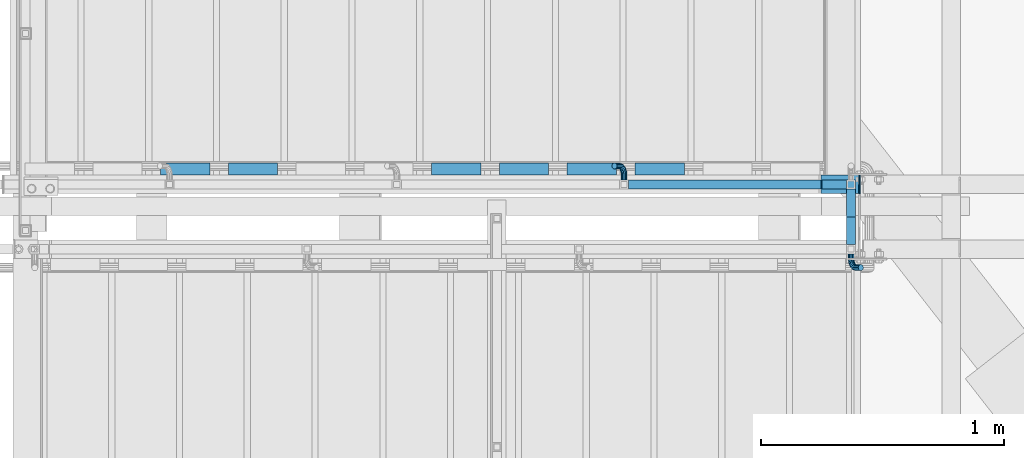
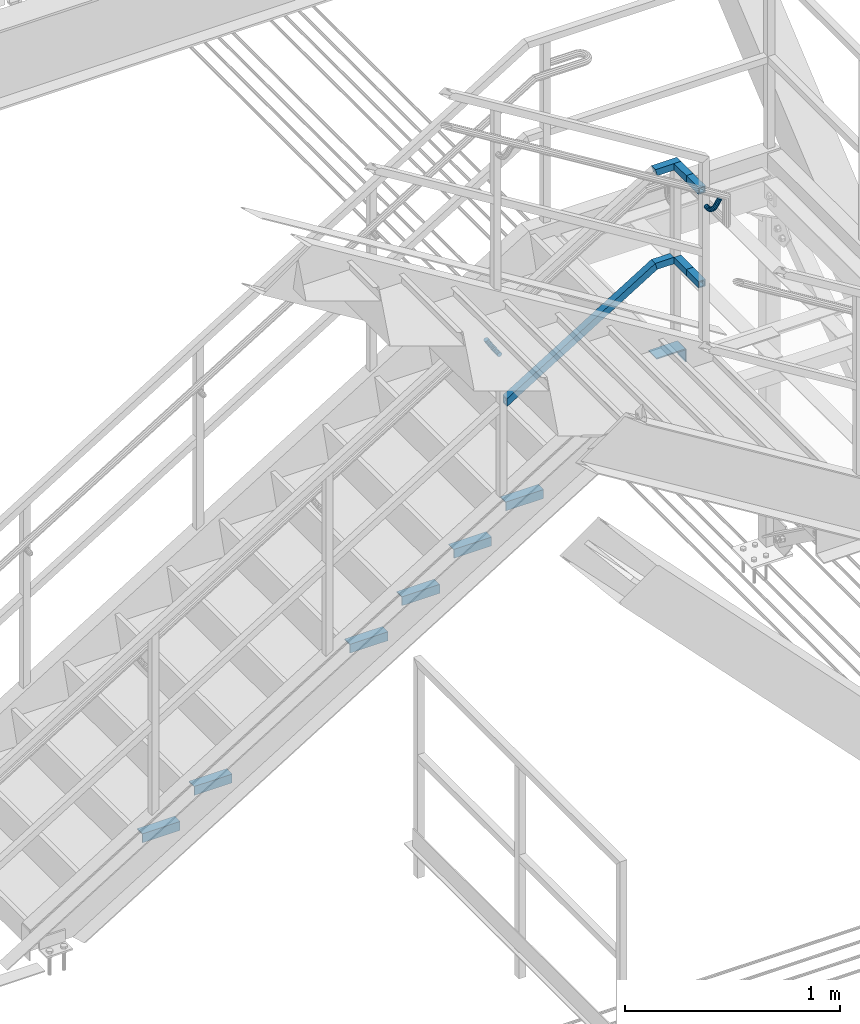
# One storey, part 2587 of 3843: 12 beams, 5 members, 3 elements without a shape of their own.
"""IFC2X3 building model written with IfcOpenShell, lengths in millimetres."""

from ifc_helpers import new_model, si_unit, frame, origin_with_axes, place, context, subcontext, project, spatial, faceted_brep, material, type_object, element, aggregate, save


model = new_model("IFC2X3")

# Units and contexts
model_context = context("Model", 3, precision=1e-05, world=origin_with_axes())
body_context = subcontext(model_context, "Body", "Model", "MODEL_VIEW")
ifc_project = project(units=[si_unit("LENGTHUNIT", "METRE", prefix="MILLI"), si_unit("AREAUNIT", "SQUARE_METRE"), si_unit("VOLUMEUNIT", "CUBIC_METRE"), si_unit("MASSUNIT", "GRAM", prefix="KILO"), si_unit("TIMEUNIT", "SECOND"), si_unit("PLANEANGLEUNIT", "RADIAN"), si_unit("SOLIDANGLEUNIT", "STERADIAN"), si_unit("THERMODYNAMICTEMPERATUREUNIT", "DEGREE_CELSIUS"), si_unit("LUMINOUSINTENSITYUNIT", "LUMEN")], contexts=[model_context])

# Site, building, storey
site_placement = place(None, origin_with_axes())
site = spatial("IfcSite", under=ifc_project, at=site_placement, CompositionType="ELEMENT")
building_placement = place(site_placement, origin_with_axes())
building = spatial("IfcBuilding", under=site, at=building_placement, Name="Undefined", CompositionType="ELEMENT")
storey_placement = place(building_placement, origin_with_axes())
storey = spatial("IfcBuildingStorey", under=building, at=storey_placement, Name="Undefined", CompositionType="ELEMENT", Elevation=0.0)

# Assembly, beams, member
assembly_1_placement = place(storey_placement, origin_with_axes())
assembly_1 = element("IfcElementAssembly", 1, at=assembly_1_placement, inside=storey, Name="RAIL", AssemblyPlace="NOTDEFINED", PredefinedType="RIGID_FRAME")
ifc_material_1 = material()
beam_type_1 = type_object("IfcBeamType", Name="HSS1-1/2X1-1/2X1/4", PredefinedType="NOTDEFINED")
beam_1_placement = place(assembly_1_placement, frame((84099.3999999465, 16725.9, 33248.5999999847), z_axis=(0.0, 0.0, 1.0), x_axis=(1.0, 0.0, 0.0)))
beam_1 = element("IfcBeam", 2, at=beam_1_placement, type_object=beam_type_1, material=ifc_material_1, Name="RAIL", ObjectType="HSS1-1/2X1-1/2X1/4", context=body_context, shape_type="Brep", body=[
    faceted_brep([(95.25000005326, -19.0499999999993, 19.0499992350015), (95.25000005326, -19.0499992350015, -19.0499992350015), (95.25000005326, 19.0499992350015, -19.0499992350015), (95.25000005326, 19.0499992350015, 19.0499992350015), (95.25000005326, -12.6999993300014, 12.6999993299978), (95.25000005326, 12.6999993300014, 12.6999993299978), (95.25000005326, 12.6999993300014, -12.6999993299978), (95.25000005326, -12.6999993300014, -12.6999993299978), (-5.39195348444628, 19.0499992350015, 19.0499992350015), (-5.39195348444628, -19.0499992350015, 19.0499992350015), (5.39195352466777, -19.0499992350015, -19.0499992350015), (5.39195352466777, 19.0499992350015, -19.0499992350015), (-3.59463560431323, 12.6999993300014, 12.6999993299978), (-3.59463560431323, -12.6999993300014, 12.6999993299978), (3.59463564452017, -12.6999993300014, -12.6999993299978), (3.59463564452017, 12.6999993300014, -12.6999993299978)], [[[0, 1, 2, 3], [4, 5, 6, 7]], [[8, 9, 0, 3]], [[10, 11, 2, 1]], [[9, 10, 1, 0]], [[11, 8, 3, 2]], [[10, 9, 8, 11], [12, 13, 14, 15]], [[14, 13, 4, 7]], [[15, 14, 7, 6]], [[12, 15, 6, 5]], [[13, 12, 5, 4]]]),
])
beam_2_placement = place(assembly_1_placement, frame((84213.6999999997, 16725.9, 33781.9999999847), z_axis=(0.0, 0.0, -1.0), x_axis=(-1.0, 0.0, 0.0)))
beam_2 = element("IfcBeam", 3, at=beam_2_placement, type_object=beam_type_1, material=ifc_material_1, Name="RAIL", ObjectType="HSS1-1/2X1-1/2X1/4", context=body_context, shape_type="Brep", body=[
    faceted_brep([(-12.6999993309546, 12.6999993299978, -12.6999993299978), (-12.6999993309546, -12.6999993299978, -12.6999993299978), (117.894635652177, -12.6999993300014, -12.6999993299978), (117.894635652177, 12.6999993300014, -12.6999993299978), (12.6999993290483, -12.6999993299978, 12.6999993299978), (110.705364403344, -12.6999993300014, 12.6999993299978), (12.6999993290483, 12.6999993299978, 12.6999993299978), (110.705364403344, 12.6999993300014, 12.6999993299978), (-19.0499992359546, 19.0499992350015, -19.0499992350015), (19.0499992350015, 19.0499992350015, 19.0499992350015), (108.908046523196, 19.0499992350015, 19.0499992350015), (119.69195353231, 19.0499992350015, -19.0499992350015), (19.0499992350015, -19.0499992350015, 19.0499992350015), (108.908046523196, -19.0499992350015, 19.0499992350015), (-19.0499992359546, -19.0499992350015, -19.0499992350015), (119.69195353231, -19.0499992350015, -19.0499992350015)], [[[0, 1, 2, 3]], [[1, 4, 5, 2]], [[4, 6, 7, 5]], [[6, 0, 3, 7]], [[8, 9, 10, 11]], [[9, 12, 13, 10]], [[12, 14, 15, 13]], [[14, 8, 11, 15]], [[13, 15, 11, 10], [5, 7, 3, 2]], [[14, 12, 9, 8], [6, 4, 1, 0]]]),
])
member_type = type_object("IfcMemberType", Name="HSS1-1/2X1-1/2X1/4", PredefinedType="NOTDEFINED")
member_1_placement = place(assembly_1_placement, frame((83277.0750000237, 16725.9, 32742.553846028), z_axis=(-0.524097425775922, 0.0, 0.851658316635875), x_axis=(0.851658316635872, 0.0, 0.524097425775926)))
member_1 = element("IfcMember", 4, at=member_1_placement, type_object=member_type, material=ifc_material_1, Name="RAIL", ObjectType="HSS1-1/2X1-1/2X1/4", context=body_context, shape_type="Brep", body=[
    faceted_brep([(10.6450480494532, -19.0499992350015, -19.0499992349796), (34.091200960931, -19.0499992350015, 19.0499992349942), (34.091200960931, 19.0499992350015, 19.0499992349942), (10.6450480494532, 19.0499992350015, -19.0499992349796), (30.1835087105574, 12.6999993300014, 12.6999993299978), (30.1835087105574, -12.6999993300014, 12.6999993299978), (14.5527402998268, -12.6999993300014, -12.6999993299833), (14.5527402998268, 12.6999993300014, -12.6999993299833), (960.16545828247, 19.0499992350015, -19.049999234483), (960.16545828247, -19.0499992350015, -19.049999234483), (970.949365314184, -19.0499992350015, 19.0499992354798), (970.949365314184, 19.0499992350015, 19.0499992354798), (969.152047430267, -12.6999993300014, 12.6999993304944), (969.152047430267, 12.6999993300014, 12.6999993304944), (961.962776166358, 12.6999993300014, -12.699999329483), (961.962776166358, -12.6999993300014, -12.699999329483)], [[[0, 1, 2, 3], [4, 5, 6, 7]], [[8, 9, 0, 3]], [[9, 10, 1, 0]], [[10, 11, 2, 1]], [[11, 8, 3, 2]], [[10, 9, 8, 11], [12, 13, 14, 15]], [[13, 12, 5, 4]], [[14, 13, 4, 7]], [[15, 14, 7, 6]], [[12, 15, 6, 5]]]),
])

# Assembly, members
assembly_2_placement = place(storey_placement, origin_with_axes())
assembly_2 = element("IfcElementAssembly", 5, at=assembly_2_placement, inside=storey, Name="RAIL", AssemblyPlace="NOTDEFINED", PredefinedType="RIGID_FRAME")
member_2_placement = place(assembly_2_placement, frame((84213.6999999997, 16592.549999235, 33248.5999999847), z_axis=(0.0, 0.0, -1.0), x_axis=(0.0, -1.0, 0.0)))
member_2 = element("IfcMember", 6, at=member_2_placement, type_object=member_type, material=ifc_material_1, Name="RAIL", ObjectType="HSS1-1/2X1-1/2X1/4", context=body_context, shape_type="Brep", body=[
    faceted_brep([(0.0, 12.6999993299978, -12.6999993300014), (0.0, -12.6999993299978, -12.6999993300014), (114.299999999999, -12.6999993299978, -12.6999993299978), (114.299999999999, 12.6999993299978, -12.6999993299978), (0.0, -12.6999993299978, 12.6999993300014), (114.299999999999, -12.6999993299978, 12.6999993299978), (0.0, 12.6999993299978, 12.6999993300014), (114.299999999999, 12.6999993299978, 12.6999993299978), (0.0, 19.0500000000029, -19.0499999999993), (0.0, 19.0499992350015, 19.0499992350015), (114.299999999999, 19.0499992349942, 19.0499992350015), (114.299999999999, 19.0499992349942, -19.0499992350015), (0.0, -19.0499992350015, 19.0499992350015), (114.299999999999, -19.0499992349942, 19.0499992350015), (0.0, -19.0499992350015, -19.0499992350015), (114.299999999999, -19.0499992349942, -19.0499992350015)], [[[0, 1, 2, 3]], [[1, 4, 5, 2]], [[4, 6, 7, 5]], [[6, 0, 3, 7]], [[8, 9, 10, 11]], [[9, 12, 13, 10]], [[12, 14, 15, 13]], [[14, 8, 11, 15]], [[13, 15, 11, 10], [5, 7, 3, 2]], [[14, 12, 9, 8], [6, 4, 1, 0]]]),
])
member_3_placement = place(assembly_2_placement, frame((84213.6999999867, 16592.55, 33781.9999999847), z_axis=(0.0, 0.0, -1.0), x_axis=(0.0, -1.0, 0.0)))
member_3 = element("IfcMember", 7, at=member_3_placement, type_object=member_type, material=ifc_material_1, Name="RAIL", ObjectType="HSS1-1/2X1-1/2X1/4", context=body_context, shape_type="Brep", body=[
    faceted_brep([(0.0, 12.6999993299978, -12.6999993300014), (0.0, -12.6999993299978, -12.6999993300014), (114.299999999999, -12.6999993299978, -12.6999993299978), (114.299999999999, 12.6999993299978, -12.6999993299978), (0.0, -12.6999993299978, 12.6999993300014), (114.299999999999, -12.6999993299978, 12.6999993299978), (0.0, 12.6999993299978, 12.6999993300014), (114.299999999999, 12.6999993299978, 12.6999993299978), (0.0, 19.0500000000029, -19.0499999999993), (0.0, 19.0499992350015, 19.0499992350015), (114.299999999999, 19.0499992349942, 19.0499992350015), (114.299999999999, 19.0499992349942, -19.0499992350015), (0.0, -19.0499992350015, 19.0499992350015), (114.299999999999, -19.0499992349942, 19.0499992350015), (0.0, -19.0499992350015, -19.0499992350015), (114.299999999999, -19.0499992349942, -19.0499992350015)], [[[0, 1, 2, 3]], [[1, 4, 5, 2]], [[4, 6, 7, 5]], [[6, 0, 3, 7]], [[8, 9, 10, 11]], [[9, 12, 13, 10]], [[12, 14, 15, 13]], [[14, 8, 11, 15]], [[13, 15, 11, 10], [5, 7, 3, 2]], [[14, 12, 9, 8], [6, 4, 1, 0]]]),
])

# Member
member_4_placement = place(assembly_1_placement, frame((84213.699999235, 16725.9, 33248.600000765), z_axis=(0.0, 0.0, -1.0), x_axis=(0.0, -1.0, 0.0)))
member_4 = element("IfcMember", 8, at=member_4_placement, type_object=member_type, material=ifc_material_1, Name="RAIL", ObjectType="HSS1-1/2X1-1/2X1/4", context=body_context, shape_type="Brep", body=[
    faceted_brep([(19.0499992350015, 12.6999993299978, -12.6999993299978), (19.0499992350015, -12.6999993299978, -12.6999993299978), (133.349999999999, -12.6999993299978, -12.6999993299978), (133.349999999999, 12.6999993299978, -12.6999993299978), (19.0499992350015, -12.6999993299978, 12.6999993299978), (133.349999999999, -12.6999993299978, 12.6999993299978), (19.0499992350015, 12.6999993299978, 12.6999993299978), (133.349999999999, 12.6999993299978, 12.6999993299978), (19.0499992350015, 19.0499992350015, -19.0499992350015), (19.0499992350015, 19.0499992350015, 19.0499992350015), (133.349999999999, 19.0499992349942, 19.0499992350015), (133.349999999999, 19.0499992349942, -19.0499992350015), (19.0499992350015, -19.0499992350015, 19.0499992350015), (133.349999999999, -19.0499992349942, 19.0499992350015), (19.0499992350015, -19.0499992350015, -19.0499992350015), (133.349999999999, -19.0499992349942, -19.0499992350015)], [[[0, 1, 2, 3]], [[1, 4, 5, 2]], [[4, 6, 7, 5]], [[6, 0, 3, 7]], [[8, 9, 10, 11]], [[9, 12, 13, 10]], [[12, 14, 15, 13]], [[14, 8, 11, 15]], [[13, 15, 11, 10], [5, 7, 3, 2]], [[14, 12, 9, 8], [6, 4, 1, 0]]]),
])

member_5_placement = place(assembly_1_placement, frame((84213.6999999997, 16725.9, 33781.9999999847), z_axis=(0.0, 0.0, -1.0), x_axis=(0.0, -1.0, 0.0)))
member_5 = element("IfcMember", 9, at=member_5_placement, type_object=member_type, material=ifc_material_1, Name="RAIL", ObjectType="HSS1-1/2X1-1/2X1/4", context=body_context, shape_type="Brep", body=[
    faceted_brep([(19.0499992350015, 12.6999993299978, -12.6999993299978), (19.0499992350015, -12.6999993299978, -12.6999993299978), (133.349999999999, -12.6999993299978, -12.6999993299978), (133.349999999999, 12.6999993299978, -12.6999993299978), (19.0499992350015, -12.6999993299978, 12.6999993299978), (133.349999999999, -12.6999993299978, 12.6999993299978), (19.0499992350015, 12.6999993299978, 12.6999993299978), (133.349999999999, 12.6999993299978, 12.6999993299978), (19.0499992350015, 19.0499992350015, -19.0499992350015), (19.0499992350015, 19.0499992350015, 19.0499992350015), (133.349999999999, 19.0499992349942, 19.0499992350015), (133.349999999999, 19.0499992349942, -19.0499992350015), (19.0499992350015, -19.0499992350015, 19.0499992350015), (133.349999999999, -19.0499992349942, 19.0499992350015), (19.0499992350015, -19.0499992350015, -19.0499992350015), (133.349999999999, -19.0499992349942, -19.0499992350015)], [[[0, 1, 2, 3]], [[1, 4, 5, 2]], [[4, 6, 7, 5]], [[6, 0, 3, 7]], [[8, 9, 10, 11]], [[9, 12, 13, 10]], [[12, 14, 15, 13]], [[14, 8, 11, 15]], [[13, 15, 11, 10], [5, 7, 3, 2]], [[14, 12, 9, 8], [6, 4, 1, 0]]]),
])

# Assembly, beams
assembly_3_placement = place(storey_placement, origin_with_axes())
assembly_3 = element("IfcElementAssembly", 10, at=assembly_3_placement, inside=storey, Name="STAIR", AssemblyPlace="NOTDEFINED", PredefinedType="RIGID_FRAME")
ifc_material_2 = material(Name="STEEL/A36")
beam_type_2 = type_object("IfcBeamType", PredefinedType="NOTDEFINED")
beam_3_placement = place(assembly_3_placement, frame((84089.9697597946, 16725.9000000001, 32737.4249999982), z_axis=(0.0, 1.0, 0.0), x_axis=(1.0, 0.0, 0.0)))
beam_3 = element("IfcBeam", 11, at=beam_3_placement, type_object=beam_type_2, material=ifc_material_2, Name="PLATE", context=body_context, shape_type="Brep", body=[
    faceted_brep([(0.0, 3.17500000000291, -38.0999999999985), (0.0, 3.17500000000291, 38.0999999999985), (155.480240205783, 3.17499999999927, 38.0999999999985), (155.480240205783, 3.17499999999927, -38.0999999999985), (0.0, -3.17500000000291, 38.0999999999985), (155.480240205783, -3.17499999999927, 38.0999999999985), (0.0, -3.17500000000291, -38.0999999999985), (155.480240205783, -3.17499999999927, -38.0999999999985)], [[[0, 1, 2, 3]], [[1, 4, 5, 2]], [[4, 6, 7, 5]], [[6, 0, 3, 7]], [[5, 7, 3, 2]], [[6, 4, 1, 0]]]),
])
beam_type_3 = type_object("IfcBeamType", PredefinedType="NOTDEFINED")
beam_4_placement = place(assembly_3_placement, frame((84248.625, 16725.8999999987, 32734.2499999983), z_axis=(0.0, 1.0, 0.0), x_axis=(0.0, 0.0, -1.0)))
beam_4 = element("IfcBeam", 12, at=beam_4_placement, type_object=beam_type_3, material=ifc_material_2, Name="PLATE", context=body_context, shape_type="Brep", body=[
    faceted_brep([(0.0, 3.17500000000291, -38.0999999999985), (0.0, 3.17500000000291, 38.0999999999985), (69.8500000000022, 3.17500000000291, 38.0999999999985), (69.8500000000022, 3.17500000000291, -38.0999999999985), (0.0, -3.17500000000291, 38.0999999999985), (69.8500000000022, -3.17500000000291, 38.0999999999985), (0.0, -3.17500000000291, -38.0999999999985), (69.8500000000022, -3.17500000000291, -38.0999999999985)], [[[0, 1, 2, 3]], [[1, 4, 5, 2]], [[4, 6, 7, 5]], [[6, 0, 3, 7]], [[5, 7, 3, 2]], [[6, 4, 1, 0]]]),
])
ifc_material_3 = material(Name="STEEL/A572-50")
beam_type_4 = type_object("IfcBeamType", Name="L2X2X3/16", PredefinedType="NOTDEFINED")
beam_5_placement = place(assembly_3_placement, frame((83525.9140030504, 16789.3999999318, 32120.0096153838), z_axis=(0.0, 1.0, 0.0), x_axis=(-1.0, 0.0, 0.0)))
beam_5 = element("IfcBeam", 13, at=beam_5_placement, type_object=beam_type_4, material=ifc_material_3, Name="ANGLE", ObjectType="L2X2X3/16", context=body_context, shape_type="Brep", body=[
    faceted_brep([(0.0, 25.4000000000015, -25.4000000000015), (0.0, 25.4000000000015, 25.4000000000015), (203.199999999997, 25.4000000000015, 25.4000000000015), (203.199999999997, 25.4000000000015, -25.4000000000015), (0.0, 20.6375000000007, 25.4000000000015), (203.199999999997, 20.6375000000007, 25.4000000000015), (0.0, 20.6375000000007, -20.6375000000007), (203.199999999997, 20.6375000000007, -20.6375000000007), (0.0, -25.4000000000015, -20.6375000000007), (203.199999999997, -25.4000000000015, -20.6375000000007), (0.0, -25.4000000000015, -25.4000000000015), (203.199999999997, -25.4000000000015, -25.4000000000015)], [[[0, 1, 2, 3]], [[1, 4, 5, 2]], [[4, 6, 7, 5]], [[6, 8, 9, 7]], [[8, 10, 11, 9]], [[10, 0, 3, 11]], [[5, 7, 9, 11, 3, 2]], [[10, 8, 6, 4, 1, 0]]]),
])
beam_6_placement = place(assembly_3_placement, frame((83246.5140030504, 16789.3999999318, 31948.0711538453), z_axis=(0.0, 1.0, 0.0), x_axis=(-1.0, 0.0, 0.0)))
beam_6 = element("IfcBeam", 14, at=beam_6_placement, type_object=beam_type_4, material=ifc_material_3, Name="ANGLE", ObjectType="L2X2X3/16", context=body_context, shape_type="Brep", body=[
    faceted_brep([(0.0, 25.4000000000015, -25.4000000000015), (0.0, 25.4000000000015, 25.4000000000015), (203.199999999997, 25.4000000000015, 25.4000000000015), (203.199999999997, 25.4000000000015, -25.4000000000015), (0.0, 20.6375000000007, 25.4000000000015), (203.199999999997, 20.6375000000007, 25.4000000000015), (0.0, 20.6375000000007, -20.6375000000007), (203.199999999997, 20.6375000000007, -20.6375000000007), (0.0, -25.4000000000015, -20.6375000000007), (203.199999999997, -25.4000000000015, -20.6375000000007), (0.0, -25.4000000000015, -25.4000000000015), (203.199999999997, -25.4000000000015, -25.4000000000015)], [[[0, 1, 2, 3]], [[1, 4, 5, 2]], [[4, 6, 7, 5]], [[6, 8, 9, 7]], [[8, 10, 11, 9]], [[10, 0, 3, 11]], [[5, 7, 9, 11, 3, 2]], [[10, 8, 6, 4, 1, 0]]]),
])
beam_7_placement = place(assembly_3_placement, frame((82967.1140030504, 16789.3999999318, 31776.1326923068), z_axis=(0.0, 1.0, 0.0), x_axis=(-1.0, 0.0, 0.0)))
beam_7 = element("IfcBeam", 15, at=beam_7_placement, type_object=beam_type_4, material=ifc_material_3, Name="ANGLE", ObjectType="L2X2X3/16", context=body_context, shape_type="Brep", body=[
    faceted_brep([(0.0, 25.4000000000015, -25.4000000000015), (0.0, 25.4000000000015, 25.4000000000015), (203.199999999997, 25.4000000000015, 25.4000000000015), (203.199999999997, 25.4000000000015, -25.4000000000015), (0.0, 20.6375000000007, 25.4000000000015), (203.199999999997, 20.6375000000007, 25.4000000000015), (0.0, 20.6375000000007, -20.6375000000007), (203.199999999997, 20.6375000000007, -20.6375000000007), (0.0, -25.4000000000015, -20.6375000000007), (203.199999999997, -25.4000000000015, -20.6375000000007), (0.0, -25.4000000000015, -25.4000000000015), (203.199999999997, -25.4000000000015, -25.4000000000015)], [[[0, 1, 2, 3]], [[1, 4, 5, 2]], [[4, 6, 7, 5]], [[6, 8, 9, 7]], [[8, 10, 11, 9]], [[10, 0, 3, 11]], [[5, 7, 9, 11, 3, 2]], [[10, 8, 6, 4, 1, 0]]]),
])
beam_8_placement = place(assembly_3_placement, frame((82687.7140030505, 16789.3999999318, 31604.1942307684), z_axis=(0.0, 1.0, 0.0), x_axis=(-1.0, 0.0, 0.0)))
beam_8 = element("IfcBeam", 16, at=beam_8_placement, type_object=beam_type_4, material=ifc_material_3, Name="ANGLE", ObjectType="L2X2X3/16", context=body_context, shape_type="Brep", body=[
    faceted_brep([(0.0, 25.4000000000015, -25.4000000000015), (0.0, 25.4000000000015, 25.4000000000015), (203.199999999997, 25.4000000000015, 25.4000000000015), (203.199999999997, 25.4000000000015, -25.4000000000015), (0.0, 20.6375000000007, 25.4000000000015), (203.199999999997, 20.6375000000007, 25.4000000000015), (0.0, 20.6375000000007, -20.6375000000007), (203.199999999997, 20.6375000000007, -20.6375000000007), (0.0, -25.4000000000015, -20.6375000000007), (203.199999999997, -25.4000000000015, -20.6375000000007), (0.0, -25.4000000000015, -25.4000000000015), (203.199999999997, -25.4000000000015, -25.4000000000015)], [[[0, 1, 2, 3]], [[1, 4, 5, 2]], [[4, 6, 7, 5]], [[6, 8, 9, 7]], [[8, 10, 11, 9]], [[10, 0, 3, 11]], [[5, 7, 9, 11, 3, 2]], [[10, 8, 6, 4, 1, 0]]]),
])
beam_9_placement = place(assembly_3_placement, frame((81849.5140030505, 16789.3999999318, 31088.378846153), z_axis=(0.0, 1.0, 0.0), x_axis=(-1.0, 0.0, 0.0)))
beam_9 = element("IfcBeam", 17, at=beam_9_placement, type_object=beam_type_4, material=ifc_material_3, Name="ANGLE", ObjectType="L2X2X3/16", context=body_context, shape_type="Brep", body=[
    faceted_brep([(0.0, 25.4000000000015, -25.4000000000015), (0.0, 25.4000000000015, 25.4000000000015), (203.199999999997, 25.4000000000015, 25.4000000000015), (203.199999999997, 25.4000000000015, -25.4000000000015), (0.0, 20.6375000000007, 25.4000000000015), (203.199999999997, 20.6375000000007, 25.4000000000015), (0.0, 20.6375000000007, -20.6375000000007), (203.199999999997, 20.6375000000007, -20.6375000000007), (0.0, -25.4000000000015, -20.6375000000007), (203.199999999997, -25.4000000000015, -20.6375000000007), (0.0, -25.4000000000015, -25.4000000000015), (203.199999999997, -25.4000000000015, -25.4000000000015)], [[[0, 1, 2, 3]], [[1, 4, 5, 2]], [[4, 6, 7, 5]], [[6, 8, 9, 7]], [[8, 10, 11, 9]], [[10, 0, 3, 11]], [[5, 7, 9, 11, 3, 2]], [[10, 8, 6, 4, 1, 0]]]),
])
beam_10_placement = place(assembly_3_placement, frame((81570.1140030505, 16789.3999999318, 30916.4403846145), z_axis=(0.0, 1.0, 0.0), x_axis=(-1.0, 0.0, 0.0)))
beam_10 = element("IfcBeam", 18, at=beam_10_placement, type_object=beam_type_4, material=ifc_material_3, Name="ANGLE", ObjectType="L2X2X3/16", context=body_context, shape_type="Brep", body=[
    faceted_brep([(0.0, 25.4000000000015, -25.4000000000015), (0.0, 25.4000000000015, 25.4000000000015), (203.199999999997, 25.4000000000015, 25.4000000000015), (203.199999999997, 25.4000000000015, -25.4000000000015), (0.0, 20.6375000000007, 25.4000000000015), (203.199999999997, 20.6375000000007, 25.4000000000015), (0.0, 20.6375000000007, -20.6375000000007), (203.199999999997, 20.6375000000007, -20.6375000000007), (0.0, -25.4000000000015, -20.6375000000007), (203.199999999997, -25.4000000000015, -20.6375000000007), (0.0, -25.4000000000015, -25.4000000000015), (203.199999999997, -25.4000000000015, -25.4000000000015)], [[[0, 1, 2, 3]], [[1, 4, 5, 2]], [[4, 6, 7, 5]], [[6, 8, 9, 7]], [[8, 10, 11, 9]], [[10, 0, 3, 11]], [[5, 7, 9, 11, 3, 2]], [[10, 8, 6, 4, 1, 0]]]),
])
aggregate(assembly_3, [beam_3, beam_4, beam_5, beam_6, beam_7, beam_8, beam_9, beam_10])

# Beam
beam_type_5 = type_object("IfcBeamType", PredefinedType="NOTDEFINED")
beam_11_placement = place(assembly_2_placement, frame((84213.6999999997, 16440.15, 33713.1439883124), z_axis=(-0.851658316635873, 0.0, 0.524097425775925), x_axis=(0.0, -1.0, 0.0)))
beam_11 = element("IfcBeam", 19, at=beam_11_placement, type_object=beam_type_5, material=ifc_material_2, Name="BRACKET ARM", context=body_context, shape_type="Brep", body=[
    faceted_brep([(0.0, -12.6999999999971, 0.0), (0.0, -10.9985226280696, -6.34999999999854), (19.0500015258731, -10.9985226280623, -6.34999999999854), (19.0500015258731, -12.6999999999971, -6.33008312433958e-10), (0.0, -6.35000000000582, -10.9985226280623), (19.0500015258731, -6.34999999999854, -10.9985226280623), (0.0, 0.0, -12.6999999999971), (19.0500015258731, 0.0, -12.6999999999971), (0.0, 6.35000000000582, -10.9985226280623), (19.0500015258731, 6.34999999999854, -10.9985226280623), (0.0, 10.9985226280696, -6.34999999999854), (19.0500015258731, 10.9985226280623, -6.34999999999854), (0.0, 12.6999999999971, 0.0), (19.0500015258731, 12.6999999999971, 0.0), (0.0, 10.9985226280696, 6.34999999999854), (19.0500015258731, 10.9985226280623, 6.34999999999854), (0.0, 6.35000000000582, 10.9985226280623), (19.0500015258731, 6.34999999999854, 10.9985226280623), (0.0, 0.0, 12.6999999999971), (19.0500015258731, 0.0, 12.6999999999971), (0.0, -6.35000000000582, 10.9985226280623), (19.0500015258731, -6.34999999999854, 10.9985226280623), (0.0, -10.9985226280696, 6.34999999999854), (19.0500015258731, -10.9985226280623, 6.34999999999854), (38.4903193060891, -8.8330803677236, -3.34694050252438e-10), (37.8391921052389, -7.26112024908798, 6.34999999974389), (36.0602795104642, -2.96644533684594, 10.9985226280041), (33.6302397149266, 2.90018969451194, 12.7000000002226), (31.2001999194181, 8.76682472604443, 10.9985226285644), (29.4212873247307, 13.061499638774, 6.35000000070431), (28.7701601240115, 14.6334597580644, 7.78527464717627e-10), (29.4212873248762, 13.0614996394288, -6.34999999929278), (31.2001999196509, 8.76682472718676, -10.9985226275603), (33.6302397151885, 2.90018969582889, -12.6999999997788), (36.0602795106824, -2.96644533571089, -10.9985226281206), (37.8391921053699, -7.26112024843314, -6.35000000026048), (53.7678987435793, 3.38210125690239, -6.3499999994383), (54.9710249311902, 2.17897506880399, 5.0931703299284e-10), (50.4808968708676, 6.66910312997061, -10.9985226273784), (45.9907688103704, 11.1592311906061, -12.6999999991458), (41.5006407498004, 15.6493592510378, -10.9985226270364), (38.213638876914, 18.9363611235749, -6.34999999884167), (37.0105126890558, 20.1394873109457, 1.20053300634027e-09), (38.2136388766667, 18.9363611228473, 6.35000000115542), (41.5006407493784, 15.6493592497718, 10.9985226290883), (45.9907688098756, 11.1592311891436, 12.7000000008557), (50.4808968704456, 6.66910312870459, 10.9985226287463), (53.7678987433319, 3.38210125617479, 6.35000000055879), (64.4111202489148, 19.3108078951118, -6.34999999821594), (65.9830803677178, 18.6596806939051, 1.77533365786076e-09), (60.1164453365491, 21.0897204901557, -10.9985226262725), (54.2498103051475, 23.5197602857806, -12.6999999981927), (48.3831752736587, 25.9498000811873, -10.9985226262434), (44.0885003610601, 27.7287126756128, -6.34999999817228), (42.516540241937, 28.3798398759754, 1.83354131877422e-09), (44.08850036074, 27.7287126747688, 6.35000000183209), (48.3831752731057, 25.9498000797321, 10.9985226298813), (54.2498103045073, 23.5197602840999, 12.7000000018088), (60.1164453359961, 21.0897204886933, 10.9985226298522), (64.4111202485947, 19.3108078942678, 6.35000000178115), (68.1485226282239, 38.0999984746086, -6.3499999967753), (69.8499999999913, 38.0999984741211, 2.92493496090174e-09), (63.500000000291, 38.0999984749651, -10.9985226249628), (57.1500000003434, 38.0999984750961, -12.6999999970722), (50.8000000002939, 38.0999984749651, -10.998522625312), (46.1514773720992, 38.0999984746086, -6.34999999737192), (44.4499999999971, 38.0999984741211, 2.58296495303512e-09), (46.1514773717645, 38.0999984736336, 6.35000000262517), (50.7999999996973, 38.0999984732771, 10.9985226308127), (57.1499999996449, 38.0999984731461, 12.700000002922), (63.4999999996944, 38.0999984732771, 10.9985226311619), (68.1485226278892, 38.0999984736336, 6.35000000322179), (68.1485226280638, 76.2000000002372, -6.34999999414867), (69.8499999999913, 76.199999999757, 5.84986992180347e-09), (63.5, 76.200000000601, -10.9985226222125), (57.1499999999942, 76.2000000007247, -12.6999999941472), (50.7999999999884, 76.200000000601, -10.9985226222125), (46.1514773719246, 76.2000000002372, -6.34999999414867), (44.4499999999971, 76.199999999757, 5.84986992180347e-09), (46.1514773719246, 76.1999999992695, 6.35000000584841), (50.7999999999884, 76.1999999989057, 10.9985226339122), (57.1499999999942, 76.199999998782, 12.700000005847), (63.5, 76.1999999989057, 10.9985226339122), (68.1485226280638, 76.1999999992695, 6.35000000584841)], [[[0, 1, 2, 3]], [[1, 4, 5, 2]], [[4, 6, 7, 5]], [[6, 8, 9, 7]], [[8, 10, 11, 9]], [[10, 12, 13, 11]], [[12, 14, 15, 13]], [[14, 16, 17, 15]], [[16, 18, 19, 17]], [[18, 20, 21, 19]], [[20, 22, 23, 21]], [[22, 0, 3, 23]], [[22, 20, 18, 16, 14, 12, 10, 8, 6, 4, 1, 0]], [[23, 3, 24, 25]], [[21, 23, 25, 26]], [[19, 21, 26, 27]], [[17, 19, 27, 28]], [[15, 17, 28, 29]], [[13, 15, 29, 30]], [[11, 13, 30, 31]], [[9, 11, 31, 32]], [[7, 9, 32, 33]], [[5, 7, 33, 34]], [[2, 5, 34, 35]], [[3, 2, 35, 24]], [[35, 36, 37, 24]], [[34, 38, 36, 35]], [[33, 39, 38, 34]], [[32, 40, 39, 33]], [[31, 41, 40, 32]], [[30, 42, 41, 31]], [[29, 43, 42, 30]], [[28, 44, 43, 29]], [[27, 45, 44, 28]], [[26, 46, 45, 27]], [[25, 47, 46, 26]], [[24, 37, 47, 25]], [[36, 48, 49, 37]], [[38, 50, 48, 36]], [[39, 51, 50, 38]], [[40, 52, 51, 39]], [[41, 53, 52, 40]], [[42, 54, 53, 41]], [[43, 55, 54, 42]], [[44, 56, 55, 43]], [[45, 57, 56, 44]], [[46, 58, 57, 45]], [[47, 59, 58, 46]], [[37, 49, 59, 47]], [[48, 60, 61, 49]], [[50, 62, 60, 48]], [[51, 63, 62, 50]], [[52, 64, 63, 51]], [[53, 65, 64, 52]], [[54, 66, 65, 53]], [[55, 67, 66, 54]], [[56, 68, 67, 55]], [[57, 69, 68, 56]], [[58, 70, 69, 57]], [[59, 71, 70, 58]], [[49, 61, 71, 59]], [[61, 60, 72, 73]], [[60, 62, 74, 72]], [[62, 63, 75, 74]], [[63, 64, 76, 75]], [[64, 65, 77, 76]], [[65, 66, 78, 77]], [[66, 67, 79, 78]], [[67, 68, 80, 79]], [[68, 69, 81, 80]], [[69, 70, 82, 81]], [[70, 71, 83, 82]], [[71, 61, 73, 83]], [[74, 75, 76, 77, 78, 79, 80, 81, 82, 83, 73, 72]]]),
])

aggregate(assembly_2, [member_2, member_3, beam_11])

beam_12_placement = place(assembly_1_placement, frame((83277.9197532377, 16744.95, 33012.2330674642), z_axis=(0.851658316635872, 0.0, 0.524097425775926), x_axis=(0.0, 1.0, 0.0)))
beam_12 = element("IfcBeam", 20, at=beam_12_placement, type_object=beam_type_5, material=ifc_material_2, Name="BRACKET ARM", context=body_context, shape_type="Brep", body=[
    faceted_brep([(0.0, -12.6999999999971, 0.0), (0.0, -10.9985226280696, -6.34999999999854), (19.0500015258731, -10.9985226280623, -6.34999999999854), (19.0500015258731, -12.6999999999971, -6.33008312433958e-10), (0.0, -6.35000000000582, -10.9985226280623), (19.0500015258731, -6.34999999999854, -10.9985226280623), (0.0, 0.0, -12.6999999999971), (19.0500015258731, 0.0, -12.6999999999971), (0.0, 6.35000000000582, -10.9985226280623), (19.0500015258731, 6.34999999999854, -10.9985226280623), (0.0, 10.9985226280696, -6.34999999999854), (19.0500015258731, 10.9985226280623, -6.34999999999854), (0.0, 12.6999999999971, 0.0), (19.0500015258731, 12.6999999999971, 0.0), (0.0, 10.9985226280696, 6.34999999999854), (19.0500015258731, 10.9985226280623, 6.34999999999854), (0.0, 6.35000000000582, 10.9985226280623), (19.0500015258731, 6.34999999999854, 10.9985226280623), (0.0, 0.0, 12.6999999999971), (19.0500015258731, 0.0, 12.6999999999971), (0.0, -6.35000000000582, 10.9985226280623), (19.0500015258731, -6.34999999999854, 10.9985226280623), (0.0, -10.9985226280696, 6.34999999999854), (19.0500015258731, -10.9985226280623, 6.34999999999854), (38.4903193060891, -8.8330803677236, -3.34694050252438e-10), (37.8391921052389, -7.26112024908798, 6.34999999974389), (36.0602795104642, -2.96644533684594, 10.9985226280041), (33.6302397149266, 2.90018969451194, 12.7000000002226), (31.2001999194181, 8.76682472604443, 10.9985226285644), (29.4212873247307, 13.061499638774, 6.35000000070431), (28.7701601240115, 14.6334597580644, 7.78527464717627e-10), (29.4212873248762, 13.0614996394288, -6.34999999929278), (31.2001999196509, 8.76682472718676, -10.9985226275603), (33.6302397151885, 2.90018969582889, -12.6999999997788), (36.0602795106824, -2.96644533571089, -10.9985226281206), (37.8391921053699, -7.26112024843314, -6.35000000026048), (53.7678987435793, 3.38210125690239, -6.3499999994383), (54.9710249311902, 2.17897506880399, 5.0931703299284e-10), (50.4808968708676, 6.66910312997061, -10.9985226273784), (45.9907688103704, 11.1592311906061, -12.6999999991458), (41.5006407498004, 15.6493592510378, -10.9985226270364), (38.213638876914, 18.9363611235749, -6.34999999884167), (37.0105126890558, 20.1394873109457, 1.20053300634027e-09), (38.2136388766667, 18.9363611228473, 6.35000000115542), (41.5006407493784, 15.6493592497718, 10.9985226290883), (45.9907688098756, 11.1592311891436, 12.7000000008557), (50.4808968704456, 6.66910312870459, 10.9985226287463), (53.7678987433319, 3.38210125617479, 6.35000000055879), (64.4111202489148, 19.3108078951118, -6.34999999821594), (65.9830803677178, 18.6596806939051, 1.77533365786076e-09), (60.1164453365491, 21.0897204901557, -10.9985226262725), (54.2498103051475, 23.5197602857806, -12.6999999981927), (48.3831752736587, 25.9498000811873, -10.9985226262434), (44.0885003610601, 27.7287126756128, -6.34999999817228), (42.516540241937, 28.3798398759754, 1.83354131877422e-09), (44.08850036074, 27.7287126747688, 6.35000000183209), (48.3831752731057, 25.9498000797321, 10.9985226298813), (54.2498103045073, 23.5197602840999, 12.7000000018088), (60.1164453359961, 21.0897204886933, 10.9985226298522), (64.4111202485947, 19.3108078942678, 6.35000000178115), (68.1485226282239, 38.0999984746086, -6.3499999967753), (69.8499999999913, 38.0999984741211, 2.92493496090174e-09), (63.500000000291, 38.0999984749651, -10.9985226249628), (57.1500000003434, 38.0999984750961, -12.6999999970722), (50.8000000002939, 38.0999984749651, -10.998522625312), (46.1514773720992, 38.0999984746086, -6.34999999737192), (44.4499999999971, 38.0999984741211, 2.58296495303512e-09), (46.1514773717645, 38.0999984736336, 6.35000000262517), (50.7999999996973, 38.0999984732771, 10.9985226308127), (57.1499999996449, 38.0999984731461, 12.700000002922), (63.4999999996944, 38.0999984732771, 10.9985226311619), (68.1485226278892, 38.0999984736336, 6.35000000322179), (68.1485226280638, 76.2000000002372, -6.34999999414867), (69.8499999999913, 76.199999999757, 5.84986992180347e-09), (63.5, 76.200000000601, -10.9985226222125), (57.1499999999942, 76.2000000007247, -12.6999999941472), (50.7999999999884, 76.200000000601, -10.9985226222125), (46.1514773719246, 76.2000000002372, -6.34999999414867), (44.4499999999971, 76.199999999757, 5.84986992180347e-09), (46.1514773719246, 76.1999999992695, 6.35000000584841), (50.7999999999884, 76.1999999989057, 10.9985226339122), (57.1499999999942, 76.199999998782, 12.700000005847), (63.5, 76.1999999989057, 10.9985226339122), (68.1485226280638, 76.1999999992695, 6.35000000584841)], [[[0, 1, 2, 3]], [[1, 4, 5, 2]], [[4, 6, 7, 5]], [[6, 8, 9, 7]], [[8, 10, 11, 9]], [[10, 12, 13, 11]], [[12, 14, 15, 13]], [[14, 16, 17, 15]], [[16, 18, 19, 17]], [[18, 20, 21, 19]], [[20, 22, 23, 21]], [[22, 0, 3, 23]], [[22, 20, 18, 16, 14, 12, 10, 8, 6, 4, 1, 0]], [[23, 3, 24, 25]], [[21, 23, 25, 26]], [[19, 21, 26, 27]], [[17, 19, 27, 28]], [[15, 17, 28, 29]], [[13, 15, 29, 30]], [[11, 13, 30, 31]], [[9, 11, 31, 32]], [[7, 9, 32, 33]], [[5, 7, 33, 34]], [[2, 5, 34, 35]], [[3, 2, 35, 24]], [[35, 36, 37, 24]], [[34, 38, 36, 35]], [[33, 39, 38, 34]], [[32, 40, 39, 33]], [[31, 41, 40, 32]], [[30, 42, 41, 31]], [[29, 43, 42, 30]], [[28, 44, 43, 29]], [[27, 45, 44, 28]], [[26, 46, 45, 27]], [[25, 47, 46, 26]], [[24, 37, 47, 25]], [[36, 48, 49, 37]], [[38, 50, 48, 36]], [[39, 51, 50, 38]], [[40, 52, 51, 39]], [[41, 53, 52, 40]], [[42, 54, 53, 41]], [[43, 55, 54, 42]], [[44, 56, 55, 43]], [[45, 57, 56, 44]], [[46, 58, 57, 45]], [[47, 59, 58, 46]], [[37, 49, 59, 47]], [[48, 60, 61, 49]], [[50, 62, 60, 48]], [[51, 63, 62, 50]], [[52, 64, 63, 51]], [[53, 65, 64, 52]], [[54, 66, 65, 53]], [[55, 67, 66, 54]], [[56, 68, 67, 55]], [[57, 69, 68, 56]], [[58, 70, 69, 57]], [[59, 71, 70, 58]], [[49, 61, 71, 59]], [[61, 60, 72, 73]], [[60, 62, 74, 72]], [[62, 63, 75, 74]], [[63, 64, 76, 75]], [[64, 65, 77, 76]], [[65, 66, 78, 77]], [[66, 67, 79, 78]], [[67, 68, 80, 79]], [[68, 69, 81, 80]], [[69, 70, 82, 81]], [[70, 71, 83, 82]], [[71, 61, 73, 83]], [[74, 75, 76, 77, 78, 79, 80, 81, 82, 83, 73, 72]]]),
])

aggregate(assembly_1, [beam_1, member_1, beam_2, member_4, member_5, beam_12])

save(model, "model.ifc")
